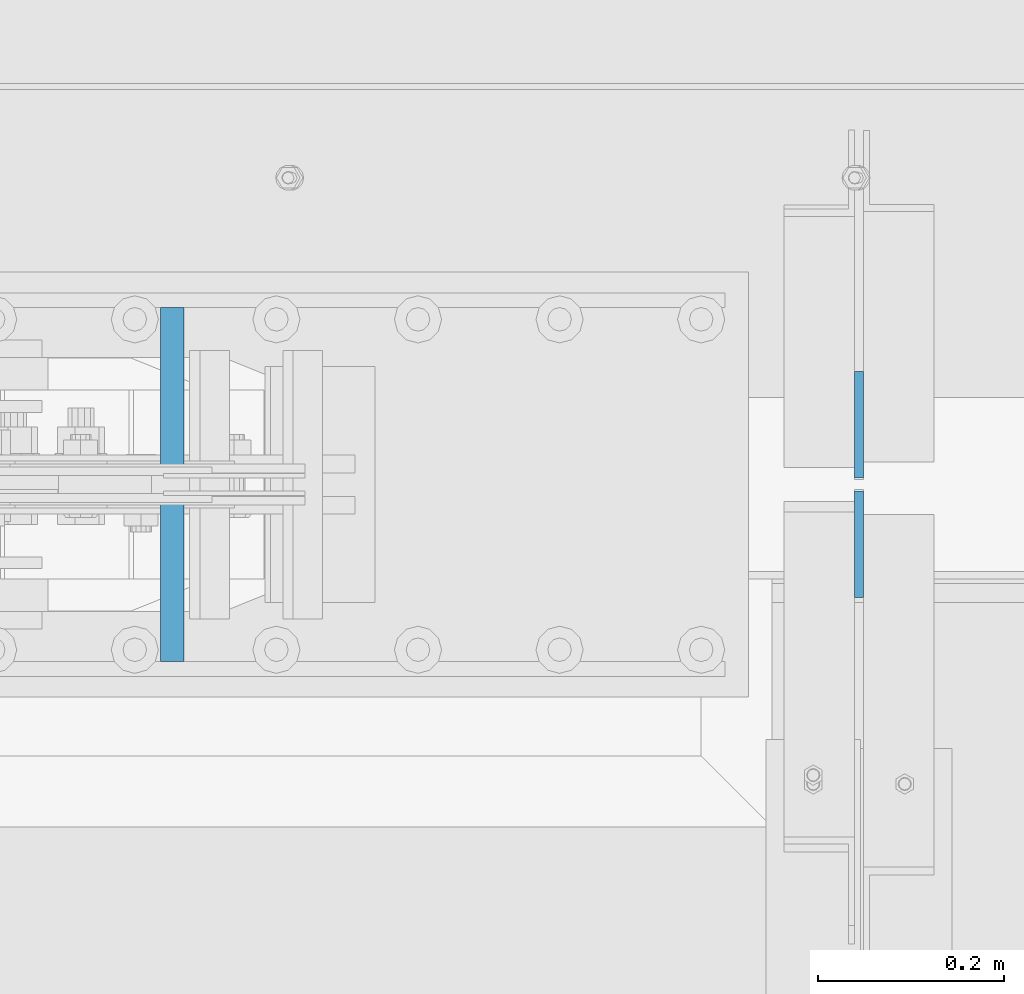
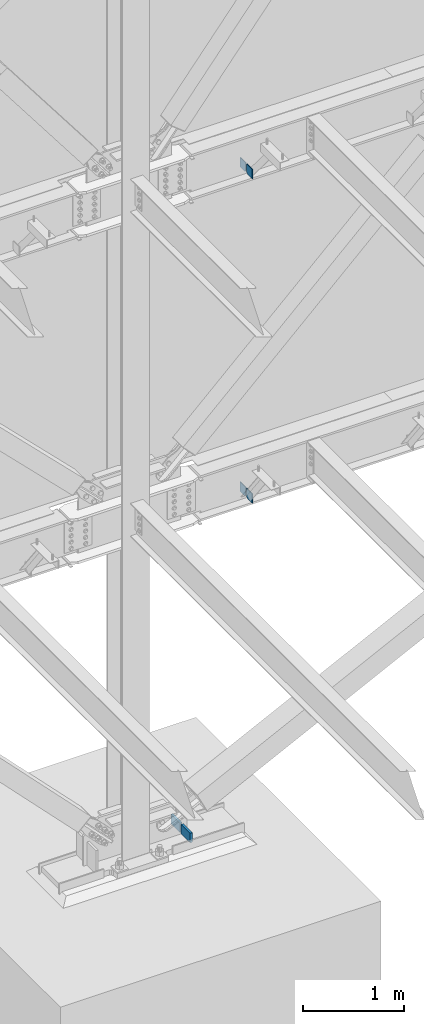
# One storey, part 533 of 1179: 6 columns, 4 elements without a shape of their own.
"""IFC2X3 building model written with IfcOpenShell, lengths in millimetres."""

from ifc_helpers import new_model, si_unit, frame, origin_with_axes, place, context, subcontext, project, spatial, faceted_brep, material, type_object, element, aggregate, save


model = new_model("IFC2X3")

# Units and contexts
model_context = context("Model", 3, precision=1e-05, world=origin_with_axes())
body_context = subcontext(model_context, "Body", "Model", "MODEL_VIEW")
ifc_project = project(units=[si_unit("LENGTHUNIT", "METRE", prefix="MILLI"), si_unit("AREAUNIT", "SQUARE_METRE"), si_unit("VOLUMEUNIT", "CUBIC_METRE"), si_unit("MASSUNIT", "GRAM", prefix="KILO"), si_unit("TIMEUNIT", "SECOND"), si_unit("PLANEANGLEUNIT", "RADIAN"), si_unit("SOLIDANGLEUNIT", "STERADIAN"), si_unit("THERMODYNAMICTEMPERATUREUNIT", "DEGREE_CELSIUS"), si_unit("LUMINOUSINTENSITYUNIT", "LUMEN")], contexts=[model_context])

# Site, building, storey
site_placement = place(None, origin_with_axes())
site = spatial("IfcSite", under=ifc_project, at=site_placement, CompositionType="ELEMENT")
building_placement = place(site_placement, origin_with_axes())
building = spatial("IfcBuilding", under=site, at=building_placement, Name="Undefined", CompositionType="ELEMENT")
storey_placement = place(building_placement, origin_with_axes())
storey = spatial("IfcBuildingStorey", under=building, at=storey_placement, Name="Undefined", CompositionType="ELEMENT", Elevation=0.0)

# Assembly, columns
assembly_1_placement = place(storey_placement, origin_with_axes())
assembly_1 = element("IfcElementAssembly", 1, at=assembly_1_placement, inside=storey, Name="BEAM", AssemblyPlace="NOTDEFINED", PredefinedType="RIGID_FRAME")
ifc_material_1 = material(Name="STEEL/A36")
column_type_1 = type_object("IfcColumnType", PredefinedType="NOTDEFINED")
column_1_placement = place(assembly_1_placement, frame((9631.3625, 41263.09375, 7488.2375), z_axis=(0.0, -1.0, 0.0), x_axis=(0.0, 0.0, 1.0)))
column_1 = element("IfcColumn", 2, at=column_1_placement, type_object=column_type_1, material=ifc_material_1, Name="PLATE", context=body_context, shape_type="Brep", body=[
    faceted_brep([(22.2250000000004, 4.76250000000073, 57.1500000000015), (0.0, 4.76250000000073, 34.9249999999993), (0.0, -4.76250000000073, 34.9249999999993), (22.2250000000004, -4.76250000000073, 57.1500000000015), (114.300000000001, 4.76250000000073, 57.1500000000015), (114.300000000001, 4.76250000000073, -57.1500000000015), (0.0, 4.76250000000073, -57.1500000000015), (114.300000000001, -4.76250000000073, 57.1500000000015), (0.0, -4.76250000000073, -57.1500000000015), (114.300000000001, -4.76250000000073, -57.1500000000015)], [[[0, 1, 2, 3]], [[4, 5, 6, 1, 0]], [[7, 4, 0, 3]], [[8, 9, 7, 3, 2]], [[8, 6, 5, 9]], [[7, 9, 5, 4]], [[6, 8, 2, 1]]]),
])
column_2_placement = place(assembly_1_placement, frame((9631.3625, 41134.50625, 7488.2375), z_axis=(0.0, 1.0, 0.0), x_axis=(0.0, 0.0, 1.0)))
column_2 = element("IfcColumn", 3, at=column_2_placement, type_object=column_type_1, material=ifc_material_1, Name="PLATE", context=body_context, shape_type="Brep", body=[
    faceted_brep([(22.2250000000004, 4.76250000000073, 57.1500000000015), (0.0, 4.76250000000073, 34.9249999999993), (0.0, -4.76250000000073, 34.9249999999993), (22.2250000000004, -4.76250000000073, 57.1500000000015), (114.300000000001, 4.76250000000073, 57.1500000000015), (114.300000000001, 4.76250000000073, -57.1500000000015), (0.0, 4.76250000000073, -57.1500000000015), (114.300000000001, -4.76250000000073, 57.1500000000015), (0.0, -4.76250000000073, -57.1500000000015), (114.300000000001, -4.76250000000073, -57.1500000000015)], [[[0, 1, 2, 3]], [[4, 5, 6, 1, 0]], [[7, 4, 0, 3]], [[8, 9, 7, 3, 2]], [[8, 6, 5, 9]], [[7, 9, 5, 4]], [[6, 8, 2, 1]]]),
])
aggregate(assembly_1, [column_1, column_2])

assembly_2_placement = place(storey_placement, origin_with_axes())
assembly_2 = element("IfcElementAssembly", 4, at=assembly_2_placement, inside=storey, Name="BEAM", AssemblyPlace="NOTDEFINED", PredefinedType="RIGID_FRAME")
column_3_placement = place(assembly_2_placement, frame((9631.36225, 41263.093875, 3576.6375), z_axis=(0.0, -1.0, 0.0), x_axis=(0.0, 0.0, 1.0)))
column_3 = element("IfcColumn", 5, at=column_3_placement, type_object=column_type_1, material=ifc_material_1, Name="PLATE", context=body_context, shape_type="Brep", body=[
    faceted_brep([(19.0500000000002, 4.76250000000073, 57.1500000000015), (0.0, 4.76250000000073, 38.0999999999985), (0.0, -4.76250000000073, 38.0999999999985), (19.0500000000002, -4.76250000000073, 57.1500000000015), (114.300000000001, 4.76250000000073, 57.1500000000015), (114.300000000001, 4.76250000000073, -57.1500000000015), (0.0, 4.76250000000073, -57.1500000000015), (114.300000000001, -4.76250000000073, 57.1500000000015), (0.0, -4.76250000000073, -57.1500000000015), (114.300000000001, -4.76250000000073, -57.1500000000015)], [[[0, 1, 2, 3]], [[4, 5, 6, 1, 0]], [[7, 4, 0, 3]], [[8, 9, 7, 3, 2]], [[8, 6, 5, 9]], [[7, 9, 5, 4]], [[6, 8, 2, 1]]]),
])
column_4_placement = place(assembly_2_placement, frame((9631.36225, 41134.506375, 3576.6375), z_axis=(0.0, 1.0, 0.0), x_axis=(0.0, 0.0, 1.0)))
column_4 = element("IfcColumn", 6, at=column_4_placement, type_object=column_type_1, material=ifc_material_1, Name="PLATE", context=body_context, shape_type="Brep", body=[
    faceted_brep([(19.0500000000002, 4.76250000000073, 57.1500000000015), (0.0, 4.76250000000073, 38.0999999999985), (0.0, -4.76250000000073, 38.0999999999985), (19.0500000000002, -4.76250000000073, 57.1500000000015), (114.300000000001, 4.76250000000073, 57.1500000000015), (114.300000000001, 4.76250000000073, -57.1500000000015), (0.0, 4.76250000000073, -57.1500000000015), (114.300000000001, -4.76250000000073, 57.1500000000015), (0.0, -4.76250000000073, -57.1500000000015), (114.300000000001, -4.76250000000073, -57.1500000000015)], [[[0, 1, 2, 3]], [[4, 5, 6, 1, 0]], [[7, 4, 0, 3]], [[8, 9, 7, 3, 2]], [[8, 6, 5, 9]], [[7, 9, 5, 4]], [[6, 8, 2, 1]]]),
])
aggregate(assembly_2, [column_3, column_4])

# Assembly, column
assembly_3_placement = place(storey_placement, origin_with_axes())
assembly_3 = element("IfcElementAssembly", 7, at=assembly_3_placement, inside=storey, Name="PLATE", AssemblyPlace="NOTDEFINED", PredefinedType="RIGID_FRAME")
ifc_material_2 = material(Name="STEEL/A572-GR.50")
column_type_2 = type_object("IfcColumnType", PredefinedType="NOTDEFINED")
column_5_placement = place(assembly_3_placement, frame((8892.35320080347, 41300.4, -215.9), z_axis=(0.0, -1.0, 0.0), x_axis=(0.0, 0.0, 1.0)))
column_5 = element("IfcColumn", 8, at=column_5_placement, type_object=column_type_2, material=ifc_material_2, Name="PLATE", context=body_context, shape_type="Brep", body=[
    faceted_brep([(0.0, 12.6999999999998, -88.9000000000015), (0.0, 12.6999999999998, 88.9000000000015), (115.086647352876, 12.7000000000007, 88.9000000000015), (115.086647352876, 12.7000000000007, -88.9000000000015), (0.0, -12.6999999999998, 88.9000000000015), (115.086647352876, -12.7000000000007, 88.9000000000015), (0.0, -12.6999999999998, -88.9000000000015), (115.086647352876, -12.7000000000007, -88.9000000000015)], [[[0, 1, 2, 3]], [[1, 4, 5, 2]], [[4, 6, 7, 5]], [[6, 0, 3, 7]], [[5, 7, 3, 2]], [[6, 4, 1, 0]]]),
])
aggregate(assembly_3, [column_5])

assembly_4_placement = place(storey_placement, origin_with_axes())
assembly_4 = element("IfcElementAssembly", 9, at=assembly_4_placement, inside=storey, Name="PLATE", AssemblyPlace="NOTDEFINED", PredefinedType="RIGID_FRAME")
column_6_placement = place(assembly_4_placement, frame((8892.35320080347, 41097.2, -215.9), z_axis=(0.0, 1.0, 0.0), x_axis=(0.0, 0.0, 1.0)))
column_6 = element("IfcColumn", 10, at=column_6_placement, type_object=column_type_2, material=ifc_material_2, Name="PLATE", context=body_context, shape_type="Brep", body=[
    faceted_brep([(0.0, 12.6999999999998, -88.9000000000015), (0.0, 12.6999999999998, 88.9000000000015), (115.086647352876, 12.7000000000007, 88.9000000000015), (115.086647352876, 12.7000000000007, -88.9000000000015), (0.0, -12.6999999999998, 88.9000000000015), (115.086647352876, -12.7000000000007, 88.9000000000015), (0.0, -12.6999999999998, -88.9000000000015), (115.086647352876, -12.7000000000007, -88.9000000000015)], [[[0, 1, 2, 3]], [[1, 4, 5, 2]], [[4, 6, 7, 5]], [[6, 0, 3, 7]], [[5, 7, 3, 2]], [[6, 4, 1, 0]]]),
])
aggregate(assembly_4, [column_6])

save(model, "model.ifc")
